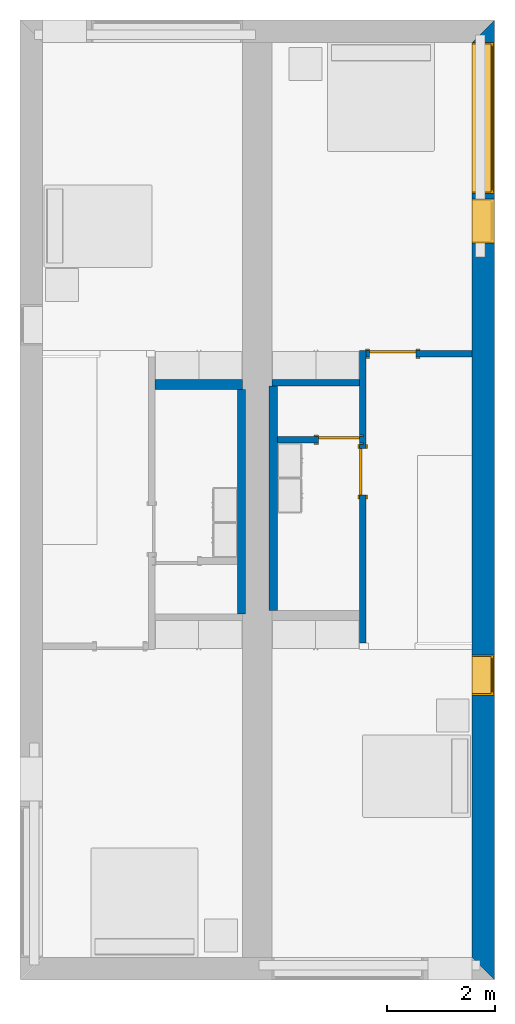
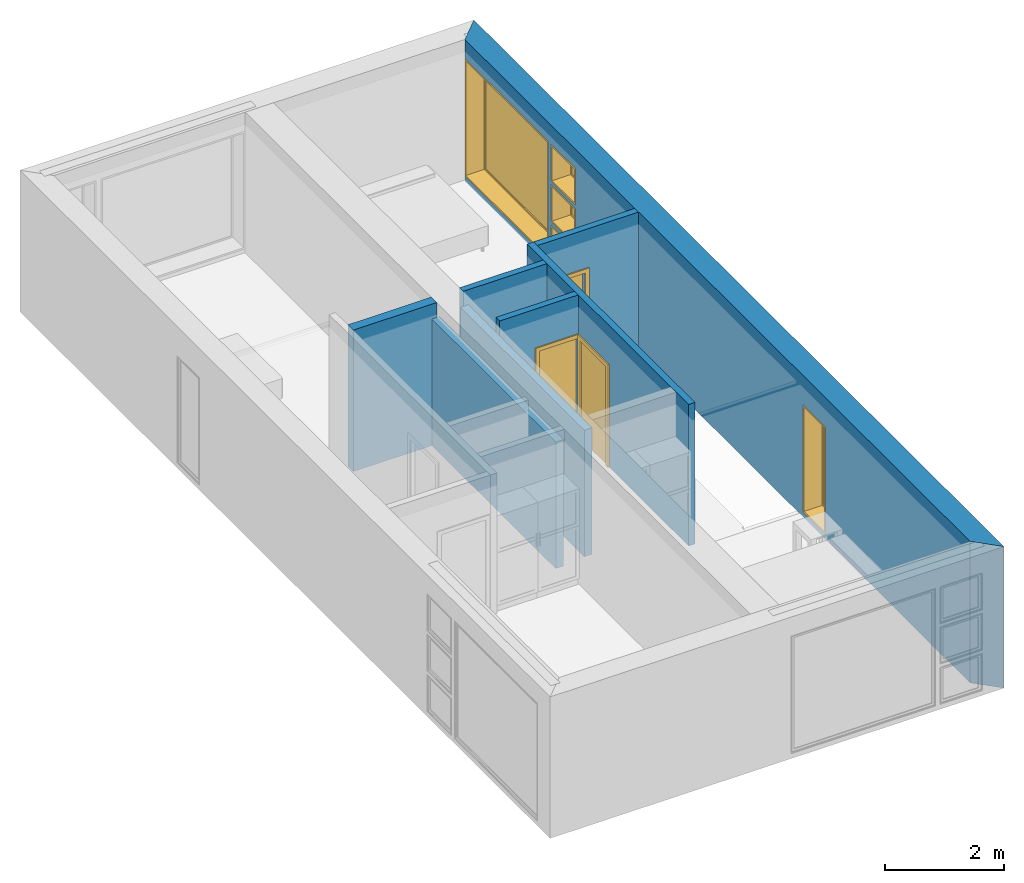
# One storey, part 3 of 16: 8 walls, 5 windows, 3 doors, 8 openings.
"""IFC2X3 building model written with IfcOpenShell, lengths in metres."""

import ifcopenshell
import ifcopenshell.guid

model = None  # the IFC model being written
_history = None  # IfcOwnerHistory: only IFC2X3 demands one
_inside = {}  # id of a spatial element -> (the spatial element, [elements in it])
_under = {}  # id of a project, library or spatial element -> (it, [spatial elements below it])
_declared = {}  # id of a project -> (the project, [libraries it declares])
_typed = {}  # id of a type object -> (the type object, [elements of that type])
_made_of = {}  # id of a material, layer set ... -> (it, [elements and type objects made of it])


def new_model(schema):
    """Start an empty IFC model of exactly this schema.

    Asked for "IFC4X3", IfcOpenShell would pick the latest addendum, in which some entities
    have other attributes; the version numbers below select the first issue.
    IFC2X3 requires an IfcOwnerHistory on every rooted entity: one is made here for all.
    """
    global model, _history
    if schema == "IFC4X3":
        model = ifcopenshell.file(schema_version=(4, 3, 0, 0))
    else:
        model = ifcopenshell.file(schema=schema)
    _inside.clear()
    _under.clear()
    _declared.clear()
    _typed.clear()
    _made_of.clear()
    _history = None
    if model.schema == "IFC2X3":
        org = make("IfcOrganization", Name="unknown")
        user = make(
            "IfcPersonAndOrganization",
            ThePerson=make("IfcPerson", FamilyName="unknown"),
            TheOrganization=org,
        )
        app = make(
            "IfcApplication",
            ApplicationDeveloper=org,
            Version="unknown",
            ApplicationFullName="unknown",
            ApplicationIdentifier="unknown",
        )
        _history = make(
            "IfcOwnerHistory",
            OwningUser=user,
            OwningApplication=app,
            ChangeAction="ADDED",
            CreationDate=0,
        )
    return model


def make(cls, **values):
    """One entity of the class cls with the attributes given. An attribute that is None is left unset."""
    return model.create_entity(
        cls, **{name: value for name, value in values.items() if value is not None}
    )


def entity(cls, *values):
    """Any entity or typed value of the class cls, its attributes in the order of the schema. None: left unset."""
    e = model.create_entity(cls)
    for i, value in enumerate(values):
        if value is not None:
            e[i] = value
    return e


def rooted(cls, **values):
    """An entity with a GlobalId (a new one), such as an element, a storey or a relation."""
    return make(cls, GlobalId=ifcopenshell.guid.new(), OwnerHistory=_history, **values)


def si_unit(unit_type, name, prefix=None):
    """IfcSIUnit, for example si_unit("LENGTHUNIT", "METRE", prefix="MILLI")."""
    return make("IfcSIUnit", UnitType=unit_type, Prefix=prefix, Name=name)


def converted_unit(unit_type, name, factor, base, dimensions=None, offset=None):
    """IfcConversionBasedUnit, such as the inch: factor (a typed value) times the base unit."""
    return make(
        "IfcConversionBasedUnit"
        if offset is None
        else "IfcConversionBasedUnitWithOffset",
        ConversionOffset=offset,
        Dimensions=None
        if dimensions is None
        else entity("IfcDimensionalExponents", *dimensions),
        UnitType=unit_type,
        Name=name,
        ConversionFactor=make(
            "IfcMeasureWithUnit", ValueComponent=factor, UnitComponent=base
        ),
    )


def assignment(units):
    """IfcUnitAssignment: the units of a project."""
    return None if units is None else make("IfcUnitAssignment", Units=units)


def point(xyz):
    """IfcCartesianPoint."""
    return None if xyz is None else make("IfcCartesianPoint", Coordinates=xyz)


def direction(xyz):
    """IfcDirection."""
    return None if xyz is None else make("IfcDirection", DirectionRatios=xyz)


def frame(location, z_axis=None, x_axis=None):
    """IfcAxis2Placement3D, a coordinate frame: its origin and axes. An axis left out is left unset."""
    return make(
        "IfcAxis2Placement3D",
        Location=point(location),
        Axis=direction(z_axis),
        RefDirection=direction(x_axis),
    )


def frame_2d(location, x_axis=None):
    """IfcAxis2Placement2D, a coordinate frame in the plane: its origin and x axis."""
    return make(
        "IfcAxis2Placement2D", Location=point(location), RefDirection=direction(x_axis)
    )


def origin():
    """The frame at (0, 0, 0) with its axes left unset."""
    return frame((0.0, 0.0, 0.0))


def origin_2d_with_axis():
    """The frame at (0, 0) in the plane with the x axis (1, 0) written out."""
    return frame_2d((0.0, 0.0), x_axis=(1.0, 0.0))


def place(relative_to, where):
    """IfcLocalPlacement: puts the frame where relative to a parent placement (None: the world)."""
    return make(
        "IfcLocalPlacement", PlacementRelTo=relative_to, RelativePlacement=where
    )


def context(
    kind, dimensions, precision=None, world=None, true_north=None, identifier=None
):
    """IfcGeometricRepresentationContext, for example the 3D "Model" context."""
    return make(
        "IfcGeometricRepresentationContext",
        ContextIdentifier=identifier,
        ContextType=kind,
        CoordinateSpaceDimension=dimensions,
        Precision=precision,
        WorldCoordinateSystem=world,
        TrueNorth=true_north,
    )


def project(units=None, contexts=None):
    """IfcProject with its units and contexts."""
    return rooted(
        "IfcProject",
        Name="project",
        RepresentationContexts=contexts,
        UnitsInContext=assignment(units),
    )


def spatial(cls, under=None, at=None, **own):
    """A site, building, storey or space (cls), placed at a placement, below another one or the project."""
    s = rooted(cls, ObjectPlacement=at, **own)
    if under is not None:
        _under.setdefault(under.id(), (under, []))[1].append(s)
    return s


def polyline(points):
    """IfcPolyline through the points."""
    return make("IfcPolyline", Points=[point(p) for p in points])


def profile(cls, at=None, kind="AREA", **sizes):
    """A parametric profile (cls). Its sizes go by their IFC names, for example OverallWidth=200.0."""
    return make(cls, ProfileType=kind, Position=at, **sizes)


def rectangle(**sizes):
    """IfcRectangleProfileDef."""
    return profile("IfcRectangleProfileDef", **sizes)


def outline(outer, holes=None, kind="AREA"):
    """IfcArbitraryClosedProfileDef: a profile drawn as a closed curve; with holes, ...WithVoids."""
    if holes is None:
        return make("IfcArbitraryClosedProfileDef", ProfileType=kind, OuterCurve=outer)
    return make(
        "IfcArbitraryProfileDefWithVoids",
        ProfileType=kind,
        OuterCurve=outer,
        InnerCurves=holes,
    )


def extrude(swept, where, along, depth):
    """IfcExtrudedAreaSolid: the profile swept, set in the frame where, extruded along a direction by depth."""
    return make(
        "IfcExtrudedAreaSolid",
        SweptArea=swept,
        Position=where,
        ExtrudedDirection=direction(along),
        Depth=depth,
    )


def shape(context_of_items, identifier, shape_type, items):
    """IfcShapeRepresentation: the items that make up one representation, for example the "Body"."""
    return make(
        "IfcShapeRepresentation",
        ContextOfItems=context_of_items,
        RepresentationIdentifier=identifier,
        RepresentationType=shape_type,
        Items=items,
    )


def source(mapping_origin, context_of_items, identifier, shape_type, items):
    """IfcRepresentationMap: a shape defined once, which mapped items show again and again."""
    return make(
        "IfcRepresentationMap",
        MappingOrigin=mapping_origin,
        MappedRepresentation=shape(context_of_items, identifier, shape_type, items),
    )


def transform(
    local_origin,
    x_axis=None,
    y_axis=None,
    z_axis=None,
    scale=None,
    scale2=None,
    scale3=None,
    uniform=True,
):
    """IfcCartesianTransformationOperator3D, or its non-uniform kind. x_axis, y_axis, z_axis: its Axis1, 2, 3."""
    if uniform:
        return make(
            "IfcCartesianTransformationOperator3D",
            Axis1=direction(x_axis),
            Axis2=direction(y_axis),
            LocalOrigin=point(local_origin),
            Scale=scale,
            Axis3=direction(z_axis),
        )
    return make(
        "IfcCartesianTransformationOperator3DnonUniform",
        Axis1=direction(x_axis),
        Axis2=direction(y_axis),
        LocalOrigin=point(local_origin),
        Scale=scale,
        Axis3=direction(z_axis),
        Scale2=scale2,
        Scale3=scale3,
    )


def mapped(mapping_source, mapping_target):
    """IfcMappedItem: shows the shape of a source again, moved by a transform."""
    return make(
        "IfcMappedItem", MappingSource=mapping_source, MappingTarget=mapping_target
    )


def material(Name=None, Category=None):
    """IfcMaterial."""
    return make("IfcMaterial", Name=Name, Category=Category)


def layer(
    of_material, thickness, ventilated=None, Name=None, Category=None, Priority=None
):
    """IfcMaterialLayer: one layer of a wall or slab, of a material (None: an air gap)."""
    return make(
        "IfcMaterialLayer",
        Material=of_material,
        LayerThickness=thickness,
        IsVentilated=ventilated,
        Name=Name,
        Category=Category,
        Priority=Priority,
    )


def layer_set(layers, Name=None):
    """IfcMaterialLayerSet."""
    return make("IfcMaterialLayerSet", MaterialLayers=layers, LayerSetName=Name)


def layer_usage(for_layer_set, set_direction, sense, offset, extent=None):
    """IfcMaterialLayerSetUsage: how a layer set lies in its element."""
    return make(
        "IfcMaterialLayerSetUsage",
        ForLayerSet=for_layer_set,
        LayerSetDirection=set_direction,
        DirectionSense=sense,
        OffsetFromReferenceLine=offset,
        ReferenceExtent=extent,
    )


def made_of(thing, what):
    """Note that an element or type object is made of a material, layer set ...; save() writes the relation."""
    if what is not None:
        _made_of.setdefault(what.id(), (what, []))[1].append(thing)
    return thing


def type_object(cls, material=None, **own):
    """A type object (cls), such as IfcWallType, which elements share."""
    return made_of(rooted(cls, **own), material)


def type_shapes(of_type, sources):
    """Give a type object the sources (RepresentationMaps) that its elements show as mapped items."""
    of_type.RepresentationMaps = sources


def element(
    cls,
    number,
    at=None,
    inside=None,
    cuts=None,
    type_object=None,
    material=None,
    context=None,
    identifier="Body",
    shape_type=None,
    held_by="IfcProductDefinitionShape",
    body=None,
    shapes=None,
    **own,
):
    """One element of the class cls, such as IfcWall. Its Tag is "e" and its number.

    at: its placement. inside: the storey or other place that contains it. cuts: it is an
    opening in that element (IfcRelVoidsElement). A single representation is given by context,
    identifier, shape_type and body (its items); several are given by shapes. held_by: the class
    of the entity that holds the representations. save() writes the other relations.
    """
    e = rooted(cls, Tag="e%d" % number, ObjectPlacement=at, **own)
    if body is not None:
        shapes = [shape(context, identifier, shape_type, body)]
    if shapes is not None:
        e.Representation = make(held_by, Representations=shapes)
    if inside is not None:
        _inside.setdefault(inside.id(), (inside, []))[1].append(e)
    if cuts is not None:
        rooted(
            "IfcRelVoidsElement", RelatingBuildingElement=cuts, RelatedOpeningElement=e
        )
    if type_object is not None:
        _typed.setdefault(type_object.id(), (type_object, []))[1].append(e)
    return made_of(e, material)


def fill(opening, filler):
    """IfcRelFillsElement: the door or window that sits in an opening."""
    return rooted(
        "IfcRelFillsElement",
        RelatingOpeningElement=opening,
        RelatedBuildingElement=filler,
    )


def aggregate(whole, parts):
    """IfcRelAggregates: a whole, such as a stair, and the parts it consists of."""
    return rooted("IfcRelAggregates", RelatingObject=whole, RelatedObjects=parts)


def save(model, path):
    """Write the relations noted so far, then the file.

    IfcRelAggregates (storeys below a building ...), IfcRelContainedInSpatialStructure (elements
    in a storey), IfcRelDefinesByType, IfcRelAssociatesMaterial and IfcRelDeclares: one each for
    every whole, place, type object, material and project.
    """
    for whole, parts in _under.values():
        aggregate(whole, parts)
    for where, things in _inside.values():
        rooted(
            "IfcRelContainedInSpatialStructure",
            RelatedElements=things,
            RelatingStructure=where,
        )
    for kind, things in _typed.values():
        rooted("IfcRelDefinesByType", RelatedObjects=things, RelatingType=kind)
    for what, things in _made_of.values():
        rooted("IfcRelAssociatesMaterial", RelatedObjects=things, RelatingMaterial=what)
    for by, libraries in _declared.values():
        rooted("IfcRelDeclares", RelatingContext=by, RelatedDefinitions=libraries)
    model.write(path)


model = new_model("IFC2X3")

# Units and contexts
model_context = context("Model", 3, precision=1e-09, world=origin())
plan_context = context("Plan", 3, precision=1e-09, world=origin())
ifc_project = project(units=[si_unit("LENGTHUNIT", "METRE"), si_unit("AREAUNIT", "SQUARE_METRE"), si_unit("VOLUMEUNIT", "CUBIC_METRE"), converted_unit("PLANEANGLEUNIT", "DEGREE", entity("IfcRatioMeasure", 0.01745329251994328), si_unit("PLANEANGLEUNIT", "RADIAN"), dimensions=[0, 0, 0, 0, 0, 0, 0]), si_unit("TIMEUNIT", "SECOND")], contexts=[model_context, plan_context])

# Site, building, storey
site_placement = place(None, origin())
site = spatial("IfcSite", under=ifc_project, at=site_placement, CompositionType="ELEMENT")
building_placement = place(site_placement, origin())
building = spatial("IfcBuilding", under=site, at=building_placement, CompositionType="ELEMENT")
storey_placement = place(building_placement, frame((0.0, 0.0, 3.100000000000196)))
storey = spatial("IfcBuildingStorey", under=building, at=storey_placement, Name="Level 2", CompositionType="ELEMENT", Elevation=3.100000000000196)

# Wall, openings, windows
ifc_material_1 = material(Name="Masonry - Brick")
ifc_layer_1 = layer(ifc_material_1, 0.092)
ifc_material_2 = material(Name="Misc. Air Layers - Air Space")
ifc_layer_2 = layer(ifc_material_2, 0.025)
ifc_material_3 = material(Name="Insulation / Thermal Barriers - Rigid insulation")
ifc_layer_3 = layer(ifc_material_3, 0.05)
ifc_material_4 = material(Name="Masonry - Concrete Block")
ifc_layer_4 = layer(ifc_material_4, 0.193)
ifc_material_5 = material(Name="Metal - Stud Layer")
ifc_layer_5 = layer(ifc_material_5, 0.041)
ifc_material_6 = material(Name="Plasterboard")
ifc_layer_6 = layer(ifc_material_6, 0.016)
ifc_layer_set_1 = layer_set([ifc_layer_1, ifc_layer_2, ifc_layer_3, ifc_layer_4, ifc_layer_5, ifc_layer_6], Name="Basic Wall:Exterior - Brick on Block")
ifc_layer_usage_1 = layer_usage(ifc_layer_set_1, "AXIS2", "NEGATIVE", 0.2085000000000001)
wall_1_placement = place(storey_placement, frame((8.5915, 0.0, 0.0), z_axis=(0.0, 0.0, 1.0), x_axis=(0.0, -1.0, 0.0)))
wall_1 = element("IfcWallStandardCase", 1, at=wall_1_placement, inside=storey, material=ifc_layer_usage_1, Name="Basic Wall:Exterior - Brick on Block", ObjectType="Basic Wall:Exterior - Brick on Block", context=model_context, shape_type="SweptSolid", body=[
    extrude(outline(polyline([(17.38299999999997, -0.2084999999999999), (17.79999999999997, 0.2085000000000002), (0.0, 0.2085000000000002), (0.4169999999999991, -0.2085000000000007), (6.125999999999979, -0.2084999999999999), (6.24999999999998, -0.2084999999999997), (17.38299999999997, -0.2084999999999999)])), origin(), (0.0, 0.0, 1.0), 2.900000000000012),
])
opening_1_placement = place(wall_1_placement, frame((0.4170000000000265, -0.2084999999999953, 0.1000000000000011)))
opening_1 = element("IfcOpeningElement", 2, at=opening_1_placement, cuts=wall_1, ObjectType="Opening", context=model_context, shape_type="SweptSolid", body=[
    extrude(rectangle(XDim=2.409999999999996, YDim=2.8, at=frame_2d((1.204999999999998, 1.4), x_axis=(1.0, 0.0))), frame((0.0, 0.0, 0.0), z_axis=(0.0, 1.0, 0.0), x_axis=(0.0, 0.0, 1.0)), (0.0, 0.0, 1.0), 0.4170000000000001),
])
opening_2_placement = place(wall_1_placement, frame((3.317000000000027, -0.2085000000000039, 1.751000000000001)))
opening_2 = element("IfcOpeningElement", 3, at=opening_2_placement, cuts=wall_1, ObjectType="Opening", context=model_context, shape_type="SweptSolid", body=[
    extrude(rectangle(XDim=0.7589999999999981, YDim=0.8189999999999995, at=frame_2d((0.379499999999999, 0.4094999999999998), x_axis=(1.0, 0.0))), frame((0.0, 0.0, 0.0), z_axis=(0.0, 1.0, 0.0), x_axis=(0.0, 0.0, 1.0)), (0.0, 0.0, 1.0), 0.4170000000000001),
])
opening_3_placement = place(wall_1_placement, frame((3.317000000000042, -0.2085000000000054, 0.9255000000000008)))
opening_3 = element("IfcOpeningElement", 4, at=opening_3_placement, cuts=wall_1, ObjectType="Opening", context=model_context, shape_type="SweptSolid", body=[
    extrude(rectangle(XDim=0.7590000000000007, YDim=0.8189999999999998, at=frame_2d((0.3795000000000003, 0.4094999999999999), x_axis=(-1.0, 0.0))), frame((0.0, 0.0, 0.0), z_axis=(0.0, 1.0, 0.0), x_axis=(0.0, 0.0, 1.0)), (0.0, 0.0, 1.0), 0.4170000000000001),
])
opening_4_placement = place(wall_1_placement, frame((3.317000000000027, -0.2085000000000039, 0.1000000000000011)))
opening_4 = element("IfcOpeningElement", 5, at=opening_4_placement, cuts=wall_1, ObjectType="Opening", context=model_context, shape_type="SweptSolid", body=[
    extrude(rectangle(XDim=0.7589999999999981, YDim=0.8189999999999995, at=frame_2d((0.3794999999999993, 0.4094999999999998), x_axis=(1.0, 0.0))), frame((0.0, 0.0, 0.0), z_axis=(0.0, 1.0, 0.0), x_axis=(0.0, 0.0, 1.0)), (0.0, 0.0, 1.0), 0.4170000000000001),
])
opening_5_placement = place(wall_1_placement, frame((11.774, -0.2085000000000172, 0.1000000000000011)))
opening_5 = element("IfcOpeningElement", 6, at=opening_5_placement, cuts=wall_1, ObjectType="Opening", context=model_context, shape_type="SweptSolid", body=[
    extrude(rectangle(XDim=2.199999999999996, YDim=0.7499999999999996, at=frame_2d((1.099999999999999, 0.3749999999999987), x_axis=(1.0, 0.0))), frame((0.0, 0.0, 0.0), z_axis=(0.0, 1.0, 0.0), x_axis=(0.0, 0.0, 1.0)), (0.0, 0.0, 1.0), 0.4170000000000001),
])
window_style_1 = type_object("IfcWindowStyle", Name="750mm x 2200mm", ConstructionType="NOTDEFINED", OperationType="NOTDEFINED", ParameterTakesPrecedence=False, Sizeable=False)
shared_shape_1 = source(origin(), model_context, "Body", "SweptSolid", [
    extrude(rectangle(XDim=0.01199999999999998, YDim=0.623999999999997, at=origin_2d_with_axis()), frame((0.375000000000007, 0.3759999999999988, 0.06299999999998514), z_axis=(0.0, 0.0, 1.0), x_axis=(0.0, -1.0, 0.0)), (0.0, 0.0, 1.0), 2.074000000000006),
    extrude(outline(polyline([(-0.3559999999999999, -1.081000000000002), (0.3559999999999999, -1.081000000000002), (0.3559999999999999, 1.081000000000002), (-0.3559999999999999, 1.081000000000002), (-0.3559999999999999, -1.081000000000002)]), holes=[polyline([(-0.3119999999999996, -1.037000000000002), (-0.3119999999999996, 1.037000000000003), (0.3119999999999975, 1.037000000000003), (0.3119999999999975, -1.037000000000002), (-0.3119999999999996, -1.037000000000002)])]), frame((0.3750000000000081, 0.3539999999999715, 1.099999999999989), z_axis=(0.0, 1.0, 0.0), x_axis=(1.0, 0.0, 0.0)), (0.0, 0.0, 1.0), 0.04400000000002743),
    extrude(outline(polyline([(-0.3749999999999997, -1.099999999999996), (0.3749999999999997, -1.099999999999996), (0.3749999999999997, 1.099999999999996), (-0.3749999999999997, 1.099999999999996), (-0.3749999999999997, -1.099999999999996)]), holes=[polyline([(-0.3560000000000012, -1.080999999999981), (-0.3560000000000013, 1.081000000000022), (0.3559999999999985, 1.081000000000022), (0.3559999999999986, -1.080999999999981), (-0.3560000000000012, -1.080999999999981)])]), frame((0.3750000000000094, 0.3539999999999715, 1.100000000000009), z_axis=(0.0, 1.0, 0.0), x_axis=(1.0, 0.0, 0.0)), (0.0, 0.0, 1.0), 0.06300000000002744),
    extrude(outline(polyline([(-0.3750000000000001, -1.099999999999996), (0.3750000000000001, -1.099999999999996), (0.3750000000000001, 1.099999999999996), (-0.3750000000000001, 1.099999999999996), (-0.3750000000000001, -1.099999999999996)]), holes=[polyline([(-0.3429999999999999, -1.067999999999982), (-0.3429999999999999, 1.06800000000002), (0.3430000000000001, 1.06800000000002), (0.3430000000000001, -1.067999999999982), (-0.3429999999999999, -1.067999999999982)])]), frame((0.3750000000000099, 0.0, 1.100000000000008), z_axis=(0.0, 1.0, 0.0), x_axis=(1.0, 0.0, 0.0)), (0.0, 0.0, 1.0), 0.3539999999999727),
])
type_shapes(window_style_1, [shared_shape_1])
window_1_placement = place(opening_5_placement, origin())
window_1 = element("IfcWindow", 7, at=window_1_placement, inside=storey, type_object=window_style_1, ObjectType="750mm x 2200mm", OverallHeight=2.199999999999997, OverallWidth=0.7499999999999984, context=model_context, shape_type="MappedRepresentation", body=[
    mapped(shared_shape_1, transform((0.0, 0.0, 0.0), scale=1.0)),
])
fill(opening_5, window_1)
window_style_2 = type_object("IfcWindowStyle", Name="2800mm x 2410mm", ConstructionType="NOTDEFINED", OperationType="NOTDEFINED", ParameterTakesPrecedence=False, Sizeable=False)
shared_shape_2 = source(origin(), model_context, "Body", "SweptSolid", [
    extrude(rectangle(XDim=0.01199999999999998, YDim=2.673999999999997, at=origin_2d_with_axis()), frame((1.400000000000007, 0.3759999999999956, 0.06299999999998514), z_axis=(0.0, 0.0, 1.0), x_axis=(0.0, -1.0, 0.0)), (0.0, 0.0, 1.0), 2.284000000000005),
    extrude(outline(polyline([(-1.381, -1.186000000000001), (1.381, -1.186000000000001), (1.381, 1.186000000000001), (-1.381, 1.186000000000001), (-1.381, -1.186000000000001)]), holes=[polyline([(-1.336999999999999, -1.142000000000002), (-1.336999999999999, 1.142000000000003), (1.336999999999997, 1.142000000000003), (1.336999999999997, -1.142000000000002), (-1.336999999999999, -1.142000000000002)])]), frame((1.400000000000008, 0.3539999999999681, 1.204999999999988), z_axis=(0.0, 1.0, 0.0), x_axis=(1.0, 0.0, 0.0)), (0.0, 0.0, 1.0), 0.04400000000002743),
    extrude(outline(polyline([(-1.4, -1.204999999999996), (1.4, -1.204999999999996), (1.4, 1.204999999999996), (-1.4, 1.204999999999996), (-1.4, -1.204999999999996)]), holes=[polyline([(-1.381000000000001, -1.185999999999981), (-1.381000000000001, 1.186000000000022), (1.380999999999999, 1.186000000000022), (1.380999999999999, -1.185999999999981), (-1.381000000000001, -1.185999999999981)])]), frame((1.400000000000009, 0.3539999999999681, 1.205000000000009), z_axis=(0.0, 1.0, 0.0), x_axis=(1.0, 0.0, 0.0)), (0.0, 0.0, 1.0), 0.06300000000002744),
    extrude(outline(polyline([(-1.4, -1.204999999999995), (1.4, -1.204999999999995), (1.4, 1.204999999999995), (-1.4, 1.204999999999995), (-1.4, -1.204999999999995)]), holes=[polyline([(-1.368, -1.172999999999982), (-1.368, 1.17300000000002), (1.368, 1.17300000000002), (1.367999999999999, -1.172999999999982), (-1.368, -1.172999999999982)])]), frame((1.40000000000001, 0.0, 1.205000000000008), z_axis=(0.0, 1.0, 0.0), x_axis=(1.0, 0.0, 0.0)), (0.0, 0.0, 1.0), 0.3539999999999727),
])
type_shapes(window_style_2, [shared_shape_2])
window_2_placement = place(opening_1_placement, origin())
window_2 = element("IfcWindow", 8, at=window_2_placement, inside=storey, type_object=window_style_2, ObjectType="2800mm x 2410mm", OverallHeight=2.409999999999996, OverallWidth=2.8, context=model_context, shape_type="MappedRepresentation", body=[
    mapped(shared_shape_2, transform((0.0, 0.0, 0.0), scale=1.0)),
])
fill(opening_1, window_2)
window_style_3 = type_object("IfcWindowStyle", Name="819mm x 759mm", ConstructionType="NOTDEFINED", OperationType="NOTDEFINED", ParameterTakesPrecedence=False, Sizeable=False)
shared_shape_3 = source(origin(), model_context, "Body", "SweptSolid", [
    extrude(rectangle(XDim=0.01199999999999998, YDim=0.6929999999999971, at=origin_2d_with_axis()), frame((0.4095000000000068, 0.3759999999999988, 0.06299999999998514), z_axis=(0.0, 0.0, 1.0), x_axis=(0.0, -1.0, 0.0)), (0.0, 0.0, 1.0), 0.6330000000000073),
    extrude(outline(polyline([(-0.3904999999999999, -0.3605000000000028), (0.3904999999999999, -0.3605000000000028), (0.3904999999999999, 0.3605000000000027), (-0.3904999999999999, 0.3605000000000027), (-0.3904999999999999, -0.3605000000000028)]), holes=[polyline([(-0.3464999999999996, -0.3165000000000033), (-0.3464999999999996, 0.316500000000004), (0.3464999999999974, 0.316500000000004), (0.3464999999999974, -0.3165000000000033), (-0.3464999999999996, -0.3165000000000033)])]), frame((0.4095000000000078, 0.3539999999999714, 0.3794999999999891), z_axis=(0.0, 1.0, 0.0), x_axis=(1.0, 0.0, 0.0)), (0.0, 0.0, 1.0), 0.04400000000002743),
    extrude(outline(polyline([(-0.4094999999999998, -0.3794999999999972), (0.4094999999999998, -0.3794999999999972), (0.4094999999999998, 0.3794999999999971), (-0.4094999999999998, 0.3794999999999971), (-0.4094999999999998, -0.3794999999999972)]), holes=[polyline([(-0.3905000000000011, -0.3604999999999823), (-0.3905000000000012, 0.3605000000000231), (0.3904999999999986, 0.3605000000000231), (0.3904999999999987, -0.3604999999999823), (-0.3905000000000011, -0.3604999999999823)])]), frame((0.4095000000000091, 0.3539999999999714, 0.3795000000000096), z_axis=(0.0, 1.0, 0.0), x_axis=(1.0, 0.0, 0.0)), (0.0, 0.0, 1.0), 0.06300000000002744),
    extrude(outline(polyline([(-0.4095000000000002, -0.3794999999999967), (0.4095000000000002, -0.3794999999999967), (0.4095000000000002, 0.3794999999999966), (-0.4095000000000002, 0.3794999999999966), (-0.4095000000000002, -0.3794999999999967)]), holes=[polyline([(-0.3774999999999999, -0.3474999999999832), (-0.3774999999999999, 0.3475000000000212), (0.3775000000000001, 0.3475000000000212), (0.3775000000000001, -0.3474999999999832), (-0.3774999999999999, -0.3474999999999832)])]), frame((0.4095000000000096, 0.0, 0.379500000000009), z_axis=(0.0, 1.0, 0.0), x_axis=(1.0, 0.0, 0.0)), (0.0, 0.0, 1.0), 0.3539999999999727),
])
type_shapes(window_style_3, [shared_shape_3])
window_3_placement = place(opening_2_placement, origin())
window_3 = element("IfcWindow", 9, at=window_3_placement, inside=storey, type_object=window_style_3, ObjectType="819mm x 759mm", OverallHeight=0.758999999999998, OverallWidth=0.8189999999999995, context=model_context, shape_type="MappedRepresentation", body=[
    mapped(shared_shape_3, transform((0.0, 0.0, 0.0), scale=1.0)),
])
fill(opening_2, window_3)
window_4_placement = place(opening_4_placement, origin())
window_4 = element("IfcWindow", 10, at=window_4_placement, inside=storey, type_object=window_style_3, ObjectType="819mm x 759mm", OverallHeight=0.7589999999999986, OverallWidth=0.8189999999999995, context=model_context, shape_type="MappedRepresentation", body=[
    mapped(shared_shape_3, transform((0.0, 0.0, 0.0), scale=1.0)),
])
fill(opening_4, window_4)
window_style_4 = type_object("IfcWindowStyle", Name="819mm x 759mm", ConstructionType="NOTDEFINED", OperationType="NOTDEFINED", ParameterTakesPrecedence=False, Sizeable=False)
shared_shape_4 = source(origin(), model_context, "Body", "SweptSolid", [
    extrude(rectangle(XDim=0.01269999999999999, YDim=0.6919999999999978, at=origin_2d_with_axis()), frame((0.4095000000000003, 0.3757750000000001, 0.06350000000000397), z_axis=(0.0, 0.0, 1.0), x_axis=(0.0, 1.0, 0.0)), (0.0, 0.0, 1.0), 0.6320000000000041),
    extrude(outline(polyline([(-0.3904499999999989, -0.3604500000000012), (0.3904499999999989, -0.3604500000000012), (0.3904499999999989, 0.3604500000000012), (-0.3904499999999989, 0.3604500000000012), (-0.3904499999999989, -0.3604500000000012)]), holes=[polyline([(-0.3459999999999978, -0.3160000000000016), (-0.3459999999999978, 0.3160000000000026), (0.346, 0.3160000000000026), (0.346, -0.3160000000000016), (-0.3459999999999978, -0.3160000000000016)])]), frame((0.4094999999999992, 0.3535500000000001, 0.3795000000000066), z_axis=(0.0, 1.0, 0.0), x_axis=(1.0, 0.0, 0.0)), (0.0, 0.0, 1.0), 0.04445),
    extrude(outline(polyline([(-0.4094999999999992, -0.3795000000000012), (0.4094999999999992, -0.3795000000000012), (0.4094999999999992, 0.3795000000000012), (-0.4094999999999992, 0.3795000000000012), (-0.4094999999999992, -0.3795000000000012)]), holes=[polyline([(-0.3777500000000001, -0.3477499999999997), (-0.3777500000000001, 0.3477500000000008), (0.3777499999999982, 0.3477500000000008), (0.3777499999999982, -0.3477499999999997), (-0.3777500000000001, -0.3477499999999997)])]), frame((0.4095000000000007, 0.0, 0.3795000000000077), z_axis=(0.0, 1.0, 0.0), x_axis=(1.0, 0.0, 0.0)), (0.0, 0.0, 1.0), 0.3535500000000001),
    extrude(outline(polyline([(-0.3795000000000017, -0.4094999999999995), (0.3795000000000017, -0.4094999999999995), (0.3795000000000017, 0.4094999999999995), (-0.3795000000000017, 0.4094999999999995), (-0.3795000000000017, -0.4094999999999995)]), holes=[polyline([(-0.3604500000000023, -0.3904499999999987), (-0.3604500000000023, 0.3904499999999997), (0.3604500000000017, 0.3904499999999997), (0.3604500000000017, -0.3904499999999988), (-0.3604500000000023, -0.3904499999999987)])]), frame((0.4095000000000004, 0.3535500000000001, 0.3795000000000071), z_axis=(0.0, 1.0, 0.0), x_axis=(0.0, 0.0, -1.0)), (0.0, 0.0, 1.0), 0.06345),
])
type_shapes(window_style_4, [shared_shape_4])
window_5_placement = place(opening_3_placement, origin())
window_5 = element("IfcWindow", 11, at=window_5_placement, inside=storey, type_object=window_style_4, ObjectType="819mm x 759mm", OverallHeight=0.7590000000000007, OverallWidth=0.8190000000000001, context=model_context, shape_type="MappedRepresentation", body=[
    mapped(shared_shape_4, transform((0.0, 0.0, 0.0), scale=1.0)),
])
fill(opening_3, window_5)

# Wall
ifc_layer_7 = layer(ifc_material_6, 0.016)
ifc_layer_8 = layer(ifc_material_5, 0.152)
ifc_layer_9 = layer(ifc_material_6, 0.016)
ifc_layer_set_2 = layer_set([ifc_layer_7, ifc_layer_8, ifc_layer_9], Name="Basic Wall:Interior - Plumbing (152mm Stud)")
ifc_layer_usage_2 = layer_usage(ifc_layer_set_2, "AXIS2", "NEGATIVE", 0.092)
wall_2_placement = place(storey_placement, frame((2.505999999999999, -6.758000000000003, 0.0)))
element("IfcWallStandardCase", 12, at=wall_2_placement, inside=storey, material=ifc_layer_usage_2, Name="Basic Wall:Interior - Plumbing (152mm Stud)", ObjectType="Basic Wall:Interior - Plumbing (152mm Stud)", context=model_context, shape_type="SweptSolid", body=[
    extrude(rectangle(XDim=1.618999999999992, YDim=0.1839999999999993, at=frame_2d((0.8094999999999958, 0.0), x_axis=(-1.0, 0.0))), origin(), (0.0, 0.0, 1.0), 2.900000000000012),
])

# Wall, opening, door
ifc_layer_10 = layer(ifc_material_6, 0.016)
ifc_layer_11 = layer(ifc_material_5, 0.092)
ifc_layer_12 = layer(ifc_material_6, 0.016)
ifc_layer_set_3 = layer_set([ifc_layer_10, ifc_layer_11, ifc_layer_12], Name="Basic Wall:Interior - Partition (92mm Stud)")
ifc_layer_usage_3 = layer_usage(ifc_layer_set_3, "AXIS2", "NEGATIVE", 0.062)
wall_3_placement = place(storey_placement, frame((6.356, -11.55, 0.0), z_axis=(0.0, 0.0, 1.0), x_axis=(0.0, 1.0, 0.0)))
wall_3 = element("IfcWallStandardCase", 13, at=wall_3_placement, inside=storey, material=ifc_layer_usage_3, Name="Basic Wall:Interior - Partition (92mm Stud)", ObjectType="Basic Wall:Interior - Partition (92mm Stud)", context=model_context, shape_type="SweptSolid", body=[
    extrude(rectangle(XDim=5.423999999999995, YDim=0.124, at=frame_2d((2.711999999999998, 0.0), x_axis=(-1.0, 0.0))), origin(), (0.0, 0.0, 1.0), 2.900000000000012),
])
opening_6_placement = place(wall_3_placement, frame((2.74061576492847, -0.0620000000000056, 0.0)))
opening_6 = element("IfcOpeningElement", 14, at=opening_6_placement, cuts=wall_3, Name="M_Single-Flush:0864 x 2032mm:0864 x 2032mm:1", ObjectType="Opening", context=model_context, shape_type="SweptSolid", body=[
    extrude(rectangle(XDim=0.8639999999999994, YDim=2.032, at=frame_2d((1.016, 0.4319999999999998), x_axis=(0.0, 1.0))), frame((0.0, 0.0, 0.0), z_axis=(0.0, 1.0, 0.0), x_axis=(0.0, 0.0, 1.0)), (0.0, 0.0, 1.0), 0.124),
])
door_style_1 = type_object("IfcDoorStyle", Name="0864 x 2032mm", ConstructionType="NOTDEFINED", OperationType="SINGLE_SWING_RIGHT", ParameterTakesPrecedence=False, Sizeable=False)
shared_shape_5 = source(origin(), model_context, "Body", "SweptSolid", [
    extrude(outline(polyline([(-0.5079999999999999, -1.072999999999999), (0.5079999999999998, -1.072999999999999), (0.5079999999999998, 1.035000000000001), (0.4319999999999997, 1.035000000000001), (0.4319999999999997, -0.9970000000000019), (-0.4319999999999996, -0.9970000000000019), (-0.4319999999999996, 1.035000000000001), (-0.5079999999999999, 1.035000000000001), (-0.5079999999999999, -1.072999999999999)])), frame((0.4320000000000008, 0.1239999999999992, 1.035000000000001), z_axis=(0.0, 1.0, 0.0), x_axis=(1.0, 0.0, 0.0)), (0.0, 0.0, 1.0), 0.02499999999999444),
    extrude(outline(polyline([(-1.073, -0.5079999999999971), (1.035, -0.5079999999999971), (1.035, -0.4320000000000073), (-0.9969999999999997, -0.4320000000000073), (-0.9969999999999997, 0.4320000000000018), (1.035, 0.4320000000000018), (1.035, 0.5080000000000027), (-1.073, 0.5080000000000027), (-1.073, -0.5079999999999971)])), frame((0.4320000000000031, -0.02500000000000638, 1.035), z_axis=(0.0, 1.0, 0.0), x_axis=(0.0, 0.0, -1.0)), (0.0, 0.0, 1.0), 0.02500000000000558),
    extrude(rectangle(XDim=0.051, YDim=0.8639999999999998, at=origin_2d_with_axis()), frame((0.4320000000000005, 0.0984999999999992, 0.0), z_axis=(0.0, 0.0, 1.0), x_axis=(0.0, 1.0, 0.0)), (0.0, 0.0, 1.0), 2.032),
])
type_shapes(door_style_1, [shared_shape_5])
door_1_placement = place(opening_6_placement, origin())
door_1 = element("IfcDoor", 15, at=door_1_placement, inside=storey, type_object=door_style_1, Name="M_Single-Flush:0864 x 2032mm:0864 x 2032mm", ObjectType="0864 x 2032mm", OverallHeight=2.032, OverallWidth=0.8639999999999995, context=model_context, shape_type="MappedRepresentation", body=[
    mapped(shared_shape_5, transform((0.0, 0.0, 0.0), scale=1.0)),
])
fill(opening_6, door_1)

ifc_layer_usage_4 = layer_usage(ifc_layer_set_3, "AXIS2", "NEGATIVE", 0.062)
wall_4_placement = place(storey_placement, frame((6.418000000000008, -6.188000000000002, 0.0)))
wall_4 = element("IfcWallStandardCase", 16, at=wall_4_placement, inside=storey, material=ifc_layer_usage_4, Name="Basic Wall:Interior - Partition (92mm Stud)", ObjectType="Basic Wall:Interior - Partition (92mm Stud)", context=model_context, shape_type="SweptSolid", body=[
    extrude(rectangle(XDim=1.964999999999982, YDim=0.124, at=frame_2d((0.982499999999991, 0.0), x_axis=(-1.0, 0.0))), origin(), (0.0, 0.0, 1.0), 2.900000000000012),
])
opening_7_placement = place(wall_4_placement, frame((0.06000000000000016, -0.0620000000000021, 0.0)))
opening_7 = element("IfcOpeningElement", 17, at=opening_7_placement, cuts=wall_4, Name="M_Single-Flush:0864 x 2032mm:0864 x 2032mm:1", ObjectType="Opening", context=model_context, shape_type="SweptSolid", body=[
    extrude(rectangle(XDim=0.8639999999999995, YDim=2.032, at=frame_2d((1.016, 0.432), x_axis=(0.0, -1.0))), frame((0.0, 0.0, 0.0), z_axis=(0.0, 1.0, 0.0), x_axis=(0.0, 0.0, 1.0)), (0.0, 0.0, 1.0), 0.124),
])
door_style_2 = type_object("IfcDoorStyle", Name="0864 x 2032mm", ConstructionType="NOTDEFINED", OperationType="SINGLE_SWING_LEFT", ParameterTakesPrecedence=False, Sizeable=False)
shared_shape_6 = source(origin(), model_context, "Body", "SweptSolid", [
    extrude(outline(polyline([(-0.5079999999999999, -1.072999999999999), (0.5079999999999998, -1.072999999999999), (0.5079999999999998, 1.035000000000001), (0.4319999999999997, 1.035000000000001), (0.4319999999999997, -0.9970000000000019), (-0.4319999999999996, -0.9970000000000019), (-0.4319999999999996, 1.035000000000001), (-0.5079999999999999, 1.035000000000001), (-0.5079999999999999, -1.072999999999999)])), frame((0.4320000000000002, 0.1489999999999882, 1.035000000000001), z_axis=(0.0, -1.0, 0.0), x_axis=(-1.0, 0.0, 0.0)), (0.0, 0.0, 1.0), 0.02499999999999444),
    extrude(outline(polyline([(-1.073, -0.5079999999999971), (1.035, -0.5079999999999971), (1.035, -0.4320000000000073), (-0.9969999999999997, -0.4320000000000073), (-0.9969999999999997, 0.4320000000000018), (1.035, 0.4320000000000018), (1.035, 0.5080000000000027), (-1.073, 0.5080000000000027), (-1.073, -0.5079999999999971)])), frame((0.4319999999999979, 0.0, 1.035), z_axis=(0.0, -1.0, 0.0), x_axis=(0.0, 0.0, -1.0)), (0.0, 0.0, 1.0), 0.02500000000000558),
    extrude(rectangle(XDim=0.8639999999999998, YDim=0.051, at=origin_2d_with_axis()), frame((0.4320000000000005, 0.09849999999999375, 0.0)), (0.0, 0.0, 1.0), 2.032),
])
type_shapes(door_style_2, [shared_shape_6])
door_2_placement = place(opening_7_placement, origin())
door_2 = element("IfcDoor", 18, at=door_2_placement, inside=storey, type_object=door_style_2, Name="M_Single-Flush:0864 x 2032mm:0864 x 2032mm", ObjectType="0864 x 2032mm", OverallHeight=2.032, OverallWidth=0.8639999999999995, context=model_context, shape_type="MappedRepresentation", body=[
    mapped(shared_shape_6, transform((0.0, 0.0, 0.0), scale=1.0)),
])
fill(opening_7, door_2)

# Walls
ifc_layer_usage_5 = layer_usage(ifc_layer_set_3, "AXIS2", "NEGATIVE", 0.062)
wall_5_placement = place(storey_placement, frame((4.674999999999989, -6.728000000000002, 0.0)))
element("IfcWallStandardCase", 19, at=wall_5_placement, inside=storey, material=ifc_layer_usage_5, Name="Basic Wall:Interior - Partition (92mm Stud)", ObjectType="Basic Wall:Interior - Partition (92mm Stud)", context=model_context, shape_type="SweptSolid", body=[
    extrude(rectangle(XDim=1.619000000000017, YDim=0.124, at=frame_2d((0.809500000000009, 0.0), x_axis=(-1.0, 0.0))), origin(), (0.0, 0.0, 1.0), 2.900000000000012),
])
ifc_layer_13 = layer(ifc_material_5, 0.136)
ifc_layer_14 = layer(ifc_material_6, 0.016)
ifc_layer_set_4 = layer_set([ifc_layer_13, ifc_layer_14], Name="Basic Wall:Interior - Furring (152 mm Stud)")
ifc_layer_usage_6 = layer_usage(ifc_layer_set_4, "AXIS2", "POSITIVE", -0.07600000000000001)
wall_6_placement = place(storey_placement, frame((4.693999999999989, -6.790000000000003, 0.0), z_axis=(0.0, 0.0, 1.0), x_axis=(0.0, -1.0, 0.0)))
element("IfcWallStandardCase", 20, at=wall_6_placement, inside=storey, material=ifc_layer_usage_6, Name="Basic Wall:Interior - Furring (152 mm Stud)", ObjectType="Basic Wall:Interior - Furring (152 mm Stud)", context=model_context, shape_type="SweptSolid", body=[
    extrude(rectangle(XDim=4.160000000000006, YDim=0.1520000000000001, at=frame_2d((2.080000000000003, 0.0), x_axis=(-1.0, 0.0))), origin(), (0.0, 0.0, 1.0), 2.595000000000012),
])
ifc_layer_usage_7 = layer_usage(ifc_layer_set_4, "AXIS2", "POSITIVE", -0.07600000000000001)
wall_7_placement = place(storey_placement, frame((4.105999999999982, -11.01, 0.0), z_axis=(0.0, 0.0, 1.0), x_axis=(0.0, 1.0, 0.0)))
element("IfcWallStandardCase", 21, at=wall_7_placement, inside=storey, material=ifc_layer_usage_7, Name="Basic Wall:Interior - Furring (152 mm Stud)", ObjectType="Basic Wall:Interior - Furring (152 mm Stud)", context=model_context, shape_type="SweptSolid", body=[
    extrude(rectangle(XDim=4.159999999999996, YDim=0.1520000000000001, at=frame_2d((2.079999999999998, 0.0), x_axis=(-1.0, 0.0))), origin(), (0.0, 0.0, 1.0), 2.595000000000012),
])

# Wall, opening, door
ifc_layer_usage_8 = layer_usage(ifc_layer_set_3, "AXIS2", "POSITIVE", -0.062)
wall_8_placement = place(storey_placement, frame((4.769999999999988, -7.783384235071523, 0.0)))
wall_8 = element("IfcWallStandardCase", 22, at=wall_8_placement, inside=storey, material=ifc_layer_usage_8, Name="Basic Wall:Interior - Partition (92mm Stud)", ObjectType="Basic Wall:Interior - Partition (92mm Stud)", context=model_context, shape_type="SweptSolid", body=[
    extrude(rectangle(XDim=1.524000000000019, YDim=0.124, at=frame_2d((0.7620000000000092, 0.0), x_axis=(-1.0, 0.0))), origin(), (0.0, 0.0, 1.0), 2.900000000000012),
])
opening_8_placement = place(wall_8_placement, frame((0.7613750000000165, -0.06200000000000323, 0.0)))
opening_8 = element("IfcOpeningElement", 23, at=opening_8_placement, cuts=wall_8, Name="M_Single-Flush:0762 x 2032mm:0762 x 2032mm:1", ObjectType="Opening", context=model_context, shape_type="SweptSolid", body=[
    extrude(rectangle(XDim=0.7619999999999997, YDim=2.032, at=frame_2d((1.016, 0.3809999999999995), x_axis=(0.0, 1.0))), frame((0.0, 0.0, 0.0), z_axis=(0.0, 1.0, 0.0), x_axis=(0.0, 0.0, 1.0)), (0.0, 0.0, 1.0), 0.124),
])
door_style_3 = type_object("IfcDoorStyle", Name="0762 x 2032mm", ConstructionType="NOTDEFINED", OperationType="SINGLE_SWING_RIGHT", ParameterTakesPrecedence=False, Sizeable=False)
shared_shape_7 = source(origin(), model_context, "Body", "SweptSolid", [
    extrude(outline(polyline([(-0.457, -1.072999999999999), (0.4569999999999999, -1.072999999999999), (0.4569999999999999, 1.035000000000001), (0.3809999999999998, 1.035000000000001), (0.3809999999999998, -0.9970000000000019), (-0.3809999999999997, -0.9970000000000019), (-0.3809999999999997, 1.035000000000001), (-0.457, 1.035000000000001), (-0.457, -1.072999999999999)])), frame((0.3810000000000009, 0.1239999999999993, 1.035000000000001), z_axis=(0.0, 1.0, 0.0), x_axis=(1.0, 0.0, 0.0)), (0.0, 0.0, 1.0), 0.02499999999999445),
    extrude(outline(polyline([(-1.073, -0.4569999999999971), (1.035, -0.4569999999999971), (1.035, -0.3810000000000074), (-0.9969999999999997, -0.3810000000000074), (-0.9969999999999997, 0.3810000000000018), (1.035, 0.3810000000000018), (1.035, 0.4570000000000027), (-1.073, 0.4570000000000027), (-1.073, -0.4569999999999971)])), frame((0.3810000000000031, -0.02500000000000627, 1.035), z_axis=(0.0, 1.0, 0.0), x_axis=(0.0, 0.0, -1.0)), (0.0, 0.0, 1.0), 0.02500000000000558),
    extrude(rectangle(XDim=0.051, YDim=0.7619999999999998, at=origin_2d_with_axis()), frame((0.3810000000000005, 0.09849999999999928, 0.0), z_axis=(0.0, 0.0, 1.0), x_axis=(0.0, 1.0, 0.0)), (0.0, 0.0, 1.0), 2.032),
])
type_shapes(door_style_3, [shared_shape_7])
door_3_placement = place(opening_8_placement, origin())
door_3 = element("IfcDoor", 24, at=door_3_placement, inside=storey, type_object=door_style_3, Name="M_Single-Flush:0762 x 2032mm:0762 x 2032mm", ObjectType="0762 x 2032mm", OverallHeight=2.032, OverallWidth=0.762, context=model_context, shape_type="MappedRepresentation", body=[
    mapped(shared_shape_7, transform((0.0, 0.0, 0.0), scale=1.0)),
])
fill(opening_8, door_3)

save(model, "model.ifc")
